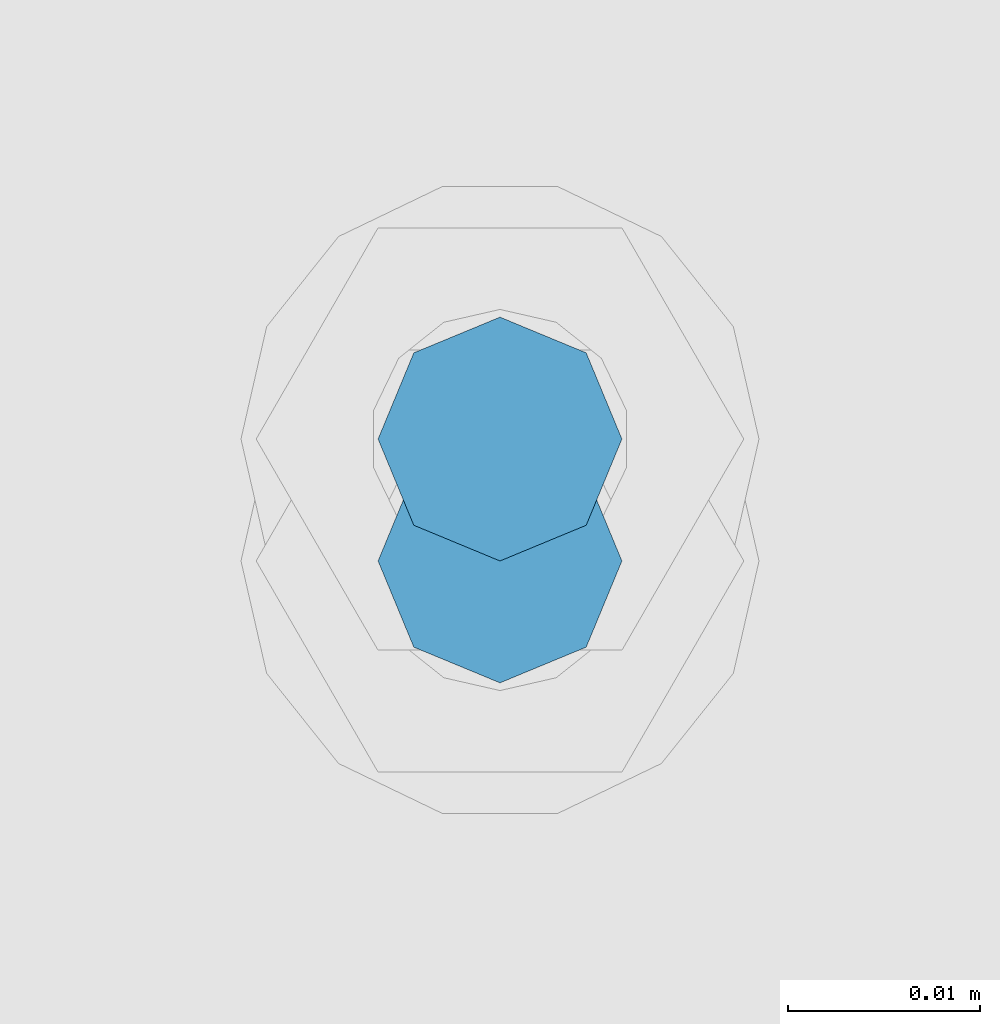
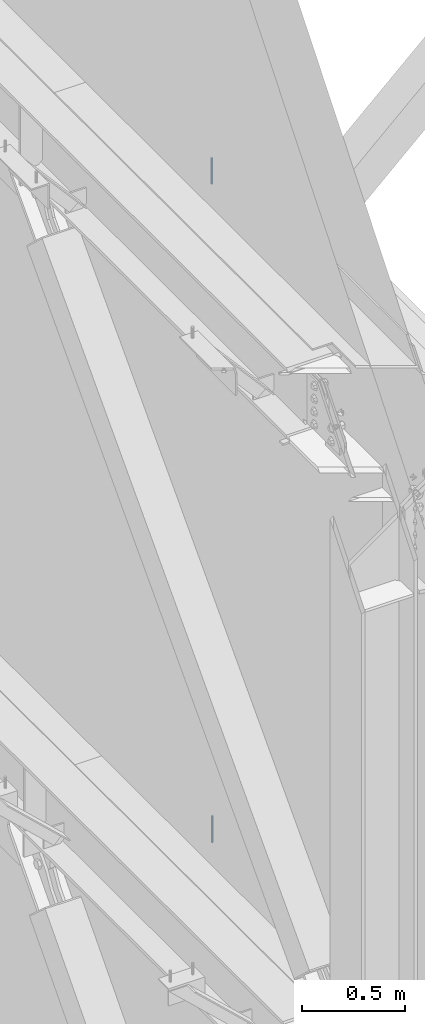
# One storey, part 472 of 1179: 2 columns, 2 elements without a shape of their own.
"""IFC2X3 building model written with IfcOpenShell, lengths in millimetres."""

import ifcopenshell
import ifcopenshell.guid

model = None  # the IFC model being written
_history = None  # IfcOwnerHistory: only IFC2X3 demands one
_inside = {}  # id of a spatial element -> (the spatial element, [elements in it])
_under = {}  # id of a project, library or spatial element -> (it, [spatial elements below it])
_declared = {}  # id of a project -> (the project, [libraries it declares])
_typed = {}  # id of a type object -> (the type object, [elements of that type])
_made_of = {}  # id of a material, layer set ... -> (it, [elements and type objects made of it])


def new_model(schema):
    """Start an empty IFC model of exactly this schema.

    Asked for "IFC4X3", IfcOpenShell would pick the latest addendum, in which some entities
    have other attributes; the version numbers below select the first issue.
    IFC2X3 requires an IfcOwnerHistory on every rooted entity: one is made here for all.
    """
    global model, _history
    if schema == "IFC4X3":
        model = ifcopenshell.file(schema_version=(4, 3, 0, 0))
    else:
        model = ifcopenshell.file(schema=schema)
    _inside.clear()
    _under.clear()
    _declared.clear()
    _typed.clear()
    _made_of.clear()
    _history = None
    if model.schema == "IFC2X3":
        org = make("IfcOrganization", Name="unknown")
        user = make(
            "IfcPersonAndOrganization",
            ThePerson=make("IfcPerson", FamilyName="unknown"),
            TheOrganization=org,
        )
        app = make(
            "IfcApplication",
            ApplicationDeveloper=org,
            Version="unknown",
            ApplicationFullName="unknown",
            ApplicationIdentifier="unknown",
        )
        _history = make(
            "IfcOwnerHistory",
            OwningUser=user,
            OwningApplication=app,
            ChangeAction="ADDED",
            CreationDate=0,
        )
    return model


def make(cls, **values):
    """One entity of the class cls with the attributes given. An attribute that is None is left unset."""
    return model.create_entity(
        cls, **{name: value for name, value in values.items() if value is not None}
    )


def rooted(cls, **values):
    """An entity with a GlobalId (a new one), such as an element, a storey or a relation."""
    return make(cls, GlobalId=ifcopenshell.guid.new(), OwnerHistory=_history, **values)


def si_unit(unit_type, name, prefix=None):
    """IfcSIUnit, for example si_unit("LENGTHUNIT", "METRE", prefix="MILLI")."""
    return make("IfcSIUnit", UnitType=unit_type, Prefix=prefix, Name=name)


def assignment(units):
    """IfcUnitAssignment: the units of a project."""
    return None if units is None else make("IfcUnitAssignment", Units=units)


def point(xyz):
    """IfcCartesianPoint."""
    return None if xyz is None else make("IfcCartesianPoint", Coordinates=xyz)


def direction(xyz):
    """IfcDirection."""
    return None if xyz is None else make("IfcDirection", DirectionRatios=xyz)


def frame(location, z_axis=None, x_axis=None):
    """IfcAxis2Placement3D, a coordinate frame: its origin and axes. An axis left out is left unset."""
    return make(
        "IfcAxis2Placement3D",
        Location=point(location),
        Axis=direction(z_axis),
        RefDirection=direction(x_axis),
    )


def origin_with_axes():
    """The frame at (0, 0, 0) with the z axis (0, 0, 1) and the x axis (1, 0, 0) written out."""
    return frame((0.0, 0.0, 0.0), z_axis=(0.0, 0.0, 1.0), x_axis=(1.0, 0.0, 0.0))


def place(relative_to, where):
    """IfcLocalPlacement: puts the frame where relative to a parent placement (None: the world)."""
    return make(
        "IfcLocalPlacement", PlacementRelTo=relative_to, RelativePlacement=where
    )


def context(
    kind, dimensions, precision=None, world=None, true_north=None, identifier=None
):
    """IfcGeometricRepresentationContext, for example the 3D "Model" context."""
    return make(
        "IfcGeometricRepresentationContext",
        ContextIdentifier=identifier,
        ContextType=kind,
        CoordinateSpaceDimension=dimensions,
        Precision=precision,
        WorldCoordinateSystem=world,
        TrueNorth=true_north,
    )


def subcontext(parent, identifier, kind, view, scale=None):
    """IfcGeometricRepresentationSubContext, for example "Body" below "Model"."""
    return make(
        "IfcGeometricRepresentationSubContext",
        ContextIdentifier=identifier,
        ContextType=kind,
        ParentContext=parent,
        TargetScale=scale,
        TargetView=view,
    )


def project(units=None, contexts=None):
    """IfcProject with its units and contexts."""
    return rooted(
        "IfcProject",
        Name="project",
        RepresentationContexts=contexts,
        UnitsInContext=assignment(units),
    )


def spatial(cls, under=None, at=None, **own):
    """A site, building, storey or space (cls), placed at a placement, below another one or the project."""
    s = rooted(cls, ObjectPlacement=at, **own)
    if under is not None:
        _under.setdefault(under.id(), (under, []))[1].append(s)
    return s


def faces_of(points, faces, orient=None, outer=None):
    """IfcFace entities. A face is a list of loops; a loop is a list of indices into points, from 0.

    orient and outer hold one flag for each loop. By default every Orientation is true, the
    first loop of a face is its IfcFaceOuterBound and the others are IfcFaceBound.
    """
    made = []
    for i, loops in enumerate(faces):
        bounds = []
        for j, loop in enumerate(loops):
            is_outer = j == 0 if outer is None else outer[i][j]
            bounds.append(
                make(
                    "IfcFaceOuterBound" if is_outer else "IfcFaceBound",
                    Bound=make("IfcPolyLoop", Polygon=[points[k] for k in loop]),
                    Orientation=True if orient is None else orient[i][j],
                )
            )
        made.append(make("IfcFace", Bounds=bounds))
    return made


def faceted_brep(points, faces, orient=None, outer=None, voids=None):
    """IfcFacetedBrep: a solid bounded by flat faces; with voids (closed shells), ...WithVoids."""
    shared = [point(p) for p in points]
    hull = make("IfcClosedShell", CfsFaces=faces_of(shared, faces, orient, outer))
    if voids is None:
        return make("IfcFacetedBrep", Outer=hull)
    return make(
        "IfcFacetedBrepWithVoids",
        Outer=hull,
        Voids=[
            make(cls, CfsFaces=faces_of(shared, fs, o, b)) for cls, fs, o, b in voids
        ],
    )


def shape(context_of_items, identifier, shape_type, items):
    """IfcShapeRepresentation: the items that make up one representation, for example the "Body"."""
    return make(
        "IfcShapeRepresentation",
        ContextOfItems=context_of_items,
        RepresentationIdentifier=identifier,
        RepresentationType=shape_type,
        Items=items,
    )


def material(Name=None, Category=None):
    """IfcMaterial."""
    return make("IfcMaterial", Name=Name, Category=Category)


def made_of(thing, what):
    """Note that an element or type object is made of a material, layer set ...; save() writes the relation."""
    if what is not None:
        _made_of.setdefault(what.id(), (what, []))[1].append(thing)
    return thing


def type_object(cls, material=None, **own):
    """A type object (cls), such as IfcWallType, which elements share."""
    return made_of(rooted(cls, **own), material)


def element(
    cls,
    number,
    at=None,
    inside=None,
    cuts=None,
    type_object=None,
    material=None,
    context=None,
    identifier="Body",
    shape_type=None,
    held_by="IfcProductDefinitionShape",
    body=None,
    shapes=None,
    **own,
):
    """One element of the class cls, such as IfcWall. Its Tag is "e" and its number.

    at: its placement. inside: the storey or other place that contains it. cuts: it is an
    opening in that element (IfcRelVoidsElement). A single representation is given by context,
    identifier, shape_type and body (its items); several are given by shapes. held_by: the class
    of the entity that holds the representations. save() writes the other relations.
    """
    e = rooted(cls, Tag="e%d" % number, ObjectPlacement=at, **own)
    if body is not None:
        shapes = [shape(context, identifier, shape_type, body)]
    if shapes is not None:
        e.Representation = make(held_by, Representations=shapes)
    if inside is not None:
        _inside.setdefault(inside.id(), (inside, []))[1].append(e)
    if cuts is not None:
        rooted(
            "IfcRelVoidsElement", RelatingBuildingElement=cuts, RelatedOpeningElement=e
        )
    if type_object is not None:
        _typed.setdefault(type_object.id(), (type_object, []))[1].append(e)
    return made_of(e, material)


def aggregate(whole, parts):
    """IfcRelAggregates: a whole, such as a stair, and the parts it consists of."""
    return rooted("IfcRelAggregates", RelatingObject=whole, RelatedObjects=parts)


def save(model, path):
    """Write the relations noted so far, then the file.

    IfcRelAggregates (storeys below a building ...), IfcRelContainedInSpatialStructure (elements
    in a storey), IfcRelDefinesByType, IfcRelAssociatesMaterial and IfcRelDeclares: one each for
    every whole, place, type object, material and project.
    """
    for whole, parts in _under.values():
        aggregate(whole, parts)
    for where, things in _inside.values():
        rooted(
            "IfcRelContainedInSpatialStructure",
            RelatedElements=things,
            RelatingStructure=where,
        )
    for kind, things in _typed.values():
        rooted("IfcRelDefinesByType", RelatedObjects=things, RelatingType=kind)
    for what, things in _made_of.values():
        rooted("IfcRelAssociatesMaterial", RelatedObjects=things, RelatingMaterial=what)
    for by, libraries in _declared.values():
        rooted("IfcRelDeclares", RelatingContext=by, RelatedDefinitions=libraries)
    model.write(path)


model = new_model("IFC2X3")

# Units and contexts
model_context = context("Model", 3, precision=1e-05, world=origin_with_axes())
body_context = subcontext(model_context, "Body", "Model", "MODEL_VIEW")
ifc_project = project(units=[si_unit("LENGTHUNIT", "METRE", prefix="MILLI"), si_unit("AREAUNIT", "SQUARE_METRE"), si_unit("VOLUMEUNIT", "CUBIC_METRE"), si_unit("MASSUNIT", "GRAM", prefix="KILO"), si_unit("TIMEUNIT", "SECOND"), si_unit("PLANEANGLEUNIT", "RADIAN"), si_unit("SOLIDANGLEUNIT", "STERADIAN"), si_unit("THERMODYNAMICTEMPERATUREUNIT", "DEGREE_CELSIUS"), si_unit("LUMINOUSINTENSITYUNIT", "LUMEN")], contexts=[model_context])

# Site, building, storey
site_placement = place(None, origin_with_axes())
site = spatial("IfcSite", under=ifc_project, at=site_placement, CompositionType="ELEMENT")
building_placement = place(site_placement, origin_with_axes())
building = spatial("IfcBuilding", under=site, at=building_placement, Name="Undefined", CompositionType="ELEMENT")
storey_placement = place(building_placement, origin_with_axes())
storey = spatial("IfcBuildingStorey", under=building, at=storey_placement, Name="Undefined", CompositionType="ELEMENT", Elevation=0.0)

# Assembly, column
assembly_1_placement = place(storey_placement, origin_with_axes())
assembly_1 = element("IfcElementAssembly", 1, at=assembly_1_placement, inside=storey, Name="BEAM", AssemblyPlace="NOTDEFINED", PredefinedType="RIGID_FRAME")
ifc_material = material(Name="STEEL/A307")
column_type = type_object("IfcColumnType", PredefinedType="NOTDEFINED")
column_1_placement = place(assembly_1_placement, frame((24638.0000051215, 29203.6500001664, 8023.22499553788), z_axis=(0.0, 1.0, 0.0), x_axis=(0.0, 0.0, 1.0)))
column_1 = element("IfcColumn", 2, at=column_1_placement, type_object=column_type, material=ifc_material, Name="THREADED ROD", context=body_context, shape_type="Brep", body=[
    faceted_brep([(0.0, -6.34999999999854, 0.0), (0.0, -4.49012806053361, -4.49012806053452), (153.987504462122, -4.49012806053361, -4.49012806053361), (153.987504462122, -6.34999999999854, 0.0), (0.0, 0.0, -6.34999999999991), (153.987504462122, 0.0, -6.34999999999854), (0.0, 4.49012806053361, -4.49012806053452), (153.987504462122, 4.49012806053361, -4.49012806053361), (0.0, 6.34999999999854, 0.0), (153.987504462122, 6.34999999999854, 0.0), (0.0, 4.49012806053361, 4.49012806053452), (153.987504462122, 4.49012806053361, 4.49012806053361), (0.0, 0.0, 6.34999999999991), (153.987504462122, 0.0, 6.34999999999854), (0.0, -4.49012806053361, 4.49012806053452), (153.987504462122, -4.49012806053361, 4.49012806053361)], [[[0, 1, 2, 3]], [[1, 4, 5, 2]], [[4, 6, 7, 5]], [[6, 8, 9, 7]], [[8, 10, 11, 9]], [[10, 12, 13, 11]], [[12, 14, 15, 13]], [[14, 0, 3, 15]], [[5, 7, 9, 11, 13, 15, 3, 2]], [[14, 12, 10, 8, 6, 4, 1, 0]]]),
])
aggregate(assembly_1, [column_1])

assembly_2_placement = place(storey_placement, origin_with_axes())
assembly_2 = element("IfcElementAssembly", 3, at=assembly_2_placement, inside=storey, Name="BEAM", AssemblyPlace="NOTDEFINED", PredefinedType="RIGID_FRAME")
column_2_placement = place(assembly_2_placement, frame((24638.0, 29197.30025, 4108.45), z_axis=(0.0, 1.0, 0.0), x_axis=(0.0, 0.0, 1.0)))
column_2 = element("IfcColumn", 4, at=column_2_placement, type_object=column_type, material=ifc_material, Name="THREADED ROD", context=body_context, shape_type="Brep", body=[
    faceted_brep([(0.0, -6.34999999999854, 0.0), (0.0, -4.49012806053361, -4.49012806053452), (157.162499999999, -4.49012806053361, -4.49012806053361), (157.162499999999, -6.34999999999854, 0.0), (0.0, 0.0, -6.34999999999991), (157.162499999999, 0.0, -6.34999999999854), (0.0, 4.49012806053361, -4.49012806053452), (157.162499999999, 4.49012806053361, -4.49012806053361), (0.0, 6.34999999999854, 0.0), (157.162499999999, 6.34999999999854, 0.0), (0.0, 4.49012806053361, 4.49012806053452), (157.162499999999, 4.49012806053361, 4.49012806053361), (0.0, 0.0, 6.34999999999991), (157.162499999999, 0.0, 6.34999999999854), (0.0, -4.49012806053361, 4.49012806053452), (157.162499999999, -4.49012806053361, 4.49012806053361)], [[[0, 1, 2, 3]], [[1, 4, 5, 2]], [[4, 6, 7, 5]], [[6, 8, 9, 7]], [[8, 10, 11, 9]], [[10, 12, 13, 11]], [[12, 14, 15, 13]], [[14, 0, 3, 15]], [[5, 7, 9, 11, 13, 15, 3, 2]], [[14, 12, 10, 8, 6, 4, 1, 0]]]),
])
aggregate(assembly_2, [column_2])

save(model, "model.ifc")
